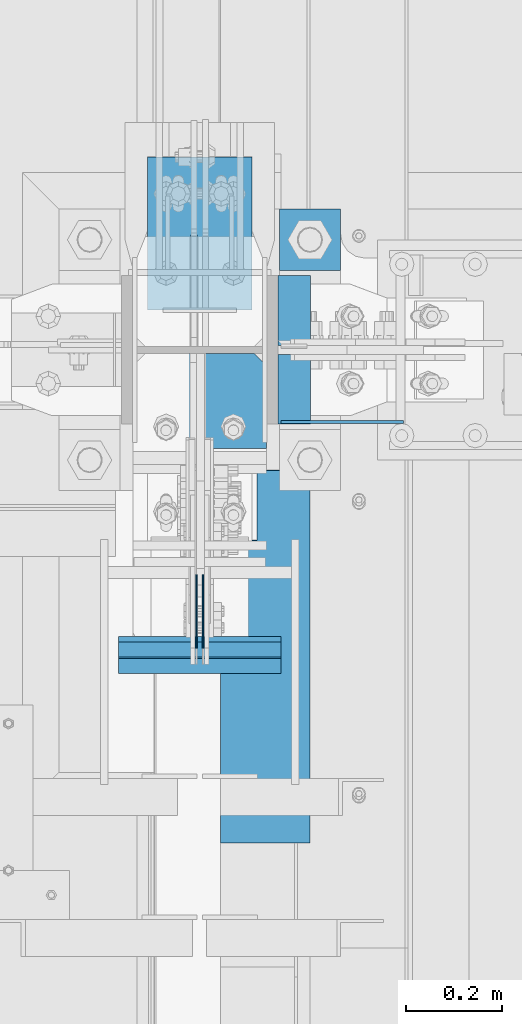
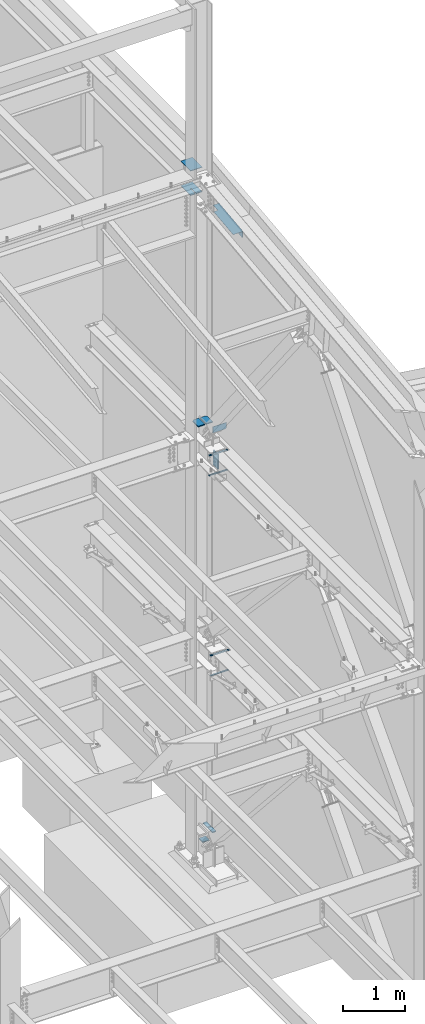
# One storey, part 894 of 1179: 15 beams, 7 elements without a shape of their own.
"""IFC2X3 building model written with IfcOpenShell, lengths in millimetres."""

from ifc_helpers import new_model, si_unit, frame, origin_with_axes, place, context, subcontext, project, spatial, faceted_brep, material, type_object, element, aggregate, save


model = new_model("IFC2X3")

# Units and contexts
model_context = context("Model", 3, precision=1e-05, world=origin_with_axes())
body_context = subcontext(model_context, "Body", "Model", "MODEL_VIEW")
ifc_project = project(units=[si_unit("LENGTHUNIT", "METRE", prefix="MILLI"), si_unit("AREAUNIT", "SQUARE_METRE"), si_unit("VOLUMEUNIT", "CUBIC_METRE"), si_unit("MASSUNIT", "GRAM", prefix="KILO"), si_unit("TIMEUNIT", "SECOND"), si_unit("PLANEANGLEUNIT", "RADIAN"), si_unit("SOLIDANGLEUNIT", "STERADIAN"), si_unit("THERMODYNAMICTEMPERATUREUNIT", "DEGREE_CELSIUS"), si_unit("LUMINOUSINTENSITYUNIT", "LUMEN")], contexts=[model_context])

# Site, building, storey
site_placement = place(None, origin_with_axes())
site = spatial("IfcSite", under=ifc_project, at=site_placement, CompositionType="ELEMENT")
building_placement = place(site_placement, origin_with_axes())
building = spatial("IfcBuilding", under=site, at=building_placement, Name="Undefined", CompositionType="ELEMENT")
storey_placement = place(building_placement, origin_with_axes())
storey = spatial("IfcBuildingStorey", under=building, at=storey_placement, Name="Undefined", CompositionType="ELEMENT", Elevation=0.0)

# Assembly, beam
assembly_1_placement = place(storey_placement, origin_with_axes())
assembly_1 = element("IfcElementAssembly", 1, at=assembly_1_placement, inside=storey, Name="TEMPLATE", AssemblyPlace="NOTDEFINED", PredefinedType="RIGID_FRAME")
ifc_material_1 = material(Name="STEEL/A36")
beam_type_1 = type_object("IfcBeamType", PredefinedType="NOTDEFINED")
beam_1_placement = place(assembly_1_placement, frame((24472.9, 34620.1999938965, -207.9625), z_axis=(0.0, 1.0, 0.0), x_axis=(1.0, 0.0, 0.0)))
beam_1 = element("IfcBeam", 2, at=beam_1_placement, type_object=beam_type_1, material=ifc_material_1, Name="SQ WASHER", context=body_context, shape_type="Brep", body=[
    faceted_brep([(0.0, 7.9375, -63.5), (0.0, 7.9375, 63.5), (127.0, 7.9375, 63.5), (127.0, 7.9375, -63.5), (0.0, -7.9375, 63.5), (127.0, -7.9375, 63.5), (0.0, -7.9375, -63.5), (127.0, -7.9375, -63.5)], [[[0, 1, 2, 3]], [[1, 4, 5, 2]], [[4, 6, 7, 5]], [[6, 0, 3, 7]], [[5, 7, 3, 2]], [[6, 4, 1, 0]]]),
])
aggregate(assembly_1, [beam_1])

# Assembly, beams
assembly_2_placement = place(storey_placement, origin_with_axes())
assembly_2 = element("IfcElementAssembly", 3, at=assembly_2_placement, inside=storey, Name="BEAM", AssemblyPlace="NOTDEFINED", PredefinedType="RIGID_FRAME")
ifc_material_2 = material(Name="STEEL/A572-GR.50")
beam_type_2 = type_object("IfcBeamType", PredefinedType="NOTDEFINED")
beam_2_placement = place(assembly_2_placement, frame((24307.8000366209, 33796.9036790882, 7589.8375), z_axis=(-1.0, 0.0, 0.0), x_axis=(0.0, -1.0, 0.0)))
beam_2 = element("IfcBeam", 4, at=beam_2_placement, type_object=beam_type_2, material=ifc_material_2, Name="PLATE", context=body_context, shape_type="Brep", body=[
    faceted_brep([(0.0, 4.76249999999982, -168.275000000001), (0.0, 4.76250000000073, 168.275), (31.75, 4.76249999999982, 168.275000000001), (31.75, 4.76249999999982, -168.275000000001), (0.0, -4.76250000000073, 168.275), (31.75, -4.76249999999982, 168.275000000001), (0.0, -4.76249999999982, -168.275000000001), (31.75, -4.76249999999982, -168.275000000001)], [[[0, 1, 2, 3]], [[1, 4, 5, 2]], [[4, 6, 7, 5]], [[6, 0, 3, 7]], [[5, 7, 3, 2]], [[6, 4, 1, 0]]]),
])
beam_3_placement = place(assembly_2_placement, frame((24307.8000366209, 33785.7911790881, 7989.4905), z_axis=(-1.0, 0.0, 0.0), x_axis=(0.0, -1.0, 0.0)))
beam_3 = element("IfcBeam", 5, at=beam_3_placement, type_object=beam_type_2, material=ifc_material_2, Name="PLATE", context=body_context, shape_type="Brep", body=[
    faceted_brep([(0.0, 4.76249999999982, -168.275000000001), (0.0, 4.76250000000073, 168.275), (31.75, 4.76249999999982, 168.275000000001), (31.75, 4.76249999999982, -168.275000000001), (0.0, -4.76250000000073, 168.275), (31.75, -4.76249999999982, 168.275000000001), (0.0, -4.76249999999982, -168.275000000001), (31.75, -4.76249999999982, -168.275000000001)], [[[0, 1, 2, 3]], [[1, 4, 5, 2]], [[4, 6, 7, 5]], [[6, 0, 3, 7]], [[5, 7, 3, 2]], [[6, 4, 1, 0]]]),
])

assembly_3_placement = place(storey_placement, origin_with_axes())
assembly_3 = element("IfcElementAssembly", 6, at=assembly_3_placement, inside=storey, Name="BEAM", AssemblyPlace="NOTDEFINED", PredefinedType="RIGID_FRAME")
beam_4_placement = place(assembly_3_placement, frame((24307.8000366209, 33762.7294989338, 3678.2375), z_axis=(-1.0, 0.0, 0.0), x_axis=(0.0, -1.0, 0.0)))
beam_4 = element("IfcBeam", 7, at=beam_4_placement, type_object=beam_type_2, material=ifc_material_2, Name="PLATE", context=body_context, shape_type="Brep", body=[
    faceted_brep([(0.0, 4.76249999999982, -168.275000000001), (0.0, 4.76250000000073, 168.275), (31.75, 4.76249999999982, 168.275000000001), (31.75, 4.76249999999982, -168.275000000001), (0.0, -4.76250000000073, 168.275), (31.75, -4.76249999999982, 168.275000000001), (0.0, -4.76249999999982, -168.275000000001), (31.75, -4.76249999999982, -168.275000000001)], [[[0, 1, 2, 3]], [[1, 4, 5, 2]], [[4, 6, 7, 5]], [[6, 0, 3, 7]], [[5, 7, 3, 2]], [[6, 4, 1, 0]]]),
])
beam_5_placement = place(assembly_3_placement, frame((24307.8000366209, 33751.6169989338, 4077.8905), z_axis=(-1.0, 0.0, 0.0), x_axis=(0.0, -1.0, 0.0)))
beam_5 = element("IfcBeam", 8, at=beam_5_placement, type_object=beam_type_2, material=ifc_material_2, Name="PLATE", context=body_context, shape_type="Brep", body=[
    faceted_brep([(0.0, 4.76249999999982, -168.275000000001), (0.0, 4.76250000000073, 168.275), (31.75, 4.76249999999982, 168.275000000001), (31.75, 4.76249999999982, -168.275000000001), (0.0, -4.76250000000073, 168.275), (31.75, -4.76249999999982, 168.275000000001), (0.0, -4.76249999999982, -168.275000000001), (31.75, -4.76249999999982, -168.275000000001)], [[[0, 1, 2, 3]], [[1, 4, 5, 2]], [[4, 6, 7, 5]], [[6, 0, 3, 7]], [[5, 7, 3, 2]], [[6, 4, 1, 0]]]),
])
aggregate(assembly_3, [beam_4, beam_5])

assembly_4_placement = place(storey_placement, origin_with_axes())
assembly_4 = element("IfcElementAssembly", 9, at=assembly_4_placement, inside=storey, Name="COLUMN", AssemblyPlace="NOTDEFINED", PredefinedType="RIGID_FRAME")
beam_type_3 = type_object("IfcBeamType", PredefinedType="NOTDEFINED")
beam_6_placement = place(assembly_4_placement, frame((24307.8000000207, 34474.9437499871, 12646.0249999739), z_axis=(1.0, 0.0, 0.0), x_axis=(0.0, 1.0, 0.0)))
beam_6 = element("IfcBeam", 10, at=beam_6_placement, type_object=beam_type_3, material=ifc_material_2, Name="PLATE", context=body_context, shape_type="Brep", body=[
    faceted_brep([(0.0, -6.35000000000036, -3.96874995145117), (0.0, 6.35000000000036, -3.96874995145117), (150.812500012864, 6.35000000000036, -3.96874995145117), (150.812500012864, -6.35000000000036, -3.96874995145117), (153.85004975726, 6.35000000000036, -4.57295616214105), (153.85004975726, -6.35000000000036, -4.57295616214105), (156.425160088533, 6.35000000000036, -6.29358987578235), (156.425160088533, -6.35000000000036, -6.29358987578235), (158.14579380217, 6.35000000000036, -8.86870020705464), (158.14579380217, -6.35000000000036, -8.86870020705464), (150.812500012864, -6.35000000000036, -19.8437499514512), (150.812500012864, 6.35000000000036, -19.8437499514512), (0.0, 6.35000000000036, -19.8437499514512), (0.0, -6.35000000000036, -19.8437499514512), (153.85004975726, -6.35000000000036, -19.2395437407613), (153.85004975726, 6.35000000000036, -19.2395437407613), (156.425160088533, -6.35000000000036, -17.51891002712), (156.425160088533, 6.35000000000036, -17.51891002712), (158.14579380217, -6.35000000000036, -14.9437996958477), (158.14579380217, 6.35000000000036, -14.9437996958477), (158.750000012864, -6.35000000000036, -11.9062499514512), (158.750000012864, 6.35000000000036, -11.9062499514512), (0.0, 6.35000000000036, 107.949999999997), (0.0, -6.35000000000036, 107.949999999997), (316.706250012867, -6.35000000000036, 107.949999999997), (316.706250012867, 6.35000000000036, 107.949999999997), (316.706250012867, -6.35000000000036, -107.949999999997), (316.706250012867, 6.35000000000036, -107.949999999997), (0.0, -6.35000000000036, -107.949999999997), (0.0, 6.35000000000036, -107.949999999997)], [[[0, 1, 2, 3]], [[3, 2, 4, 5]], [[5, 4, 6, 7]], [[7, 6, 8, 9]], [[10, 11, 12, 13]], [[14, 15, 11, 10]], [[16, 17, 15, 14]], [[18, 19, 17, 16]], [[20, 21, 19, 18]], [[9, 8, 21, 20]], [[22, 23, 24, 25]], [[24, 26, 27, 25]], [[28, 29, 27, 26]], [[29, 28, 13, 12]], [[6, 4, 2, 1, 22, 25, 27, 29, 12, 11, 15, 17, 19, 21, 8]], [[23, 22, 1, 0]], [[16, 14, 10, 13, 28, 26, 24, 23, 0, 3, 5, 7, 9, 20, 18]]]),
])
beam_7_placement = place(assembly_4_placement, frame((24307.8000000301, 34474.94375, 13125.449999951), z_axis=(1.0, 0.0, 0.0), x_axis=(0.0, 1.0, 0.0)))
beam_7 = element("IfcBeam", 11, at=beam_7_placement, type_object=beam_type_3, material=ifc_material_2, Name="PLATE", context=body_context, shape_type="Brep", body=[
    faceted_brep([(0.0, 6.35000000000036, -107.949999999997), (0.0, 6.35000000000036, 107.949999999997), (316.706250012867, 6.35000000000036, 107.949999999997), (316.706250012867, 6.35000000000036, -107.949999999997), (0.0, -6.35000000000036, 107.949999999997), (316.706250012867, -6.35000000000036, 107.949999999997), (0.0, -6.35000000000036, -107.949999999997), (316.706250012867, -6.35000000000036, -107.949999999997)], [[[0, 1, 2, 3]], [[1, 4, 5, 2]], [[4, 6, 7, 5]], [[6, 0, 3, 7]], [[5, 7, 3, 2]], [[6, 4, 1, 0]]]),
])

# Assembly, beam
assembly_5_placement = place(storey_placement, origin_with_axes())
assembly_5 = element("IfcElementAssembly", 12, at=assembly_5_placement, inside=storey, Name="PLATE", AssemblyPlace="NOTDEFINED", PredefinedType="RIGID_FRAME")
beam_type_4 = type_object("IfcBeamType", PredefinedType="NOTDEFINED")
beam_8_placement = place(assembly_5_placement, frame((24469.725, 34473.3565, 180.194274822156), z_axis=(0.0, 1.0, 0.0), x_axis=(1.0, 0.0, 0.0)))
beam_8 = element("IfcBeam", 13, at=beam_8_placement, type_object=beam_type_4, material=ifc_material_2, Name="PLATE", context=body_context, shape_type="Brep", body=[
    faceted_brep([(0.0, 9.52500000000001, -72.2315000000017), (0.0, 9.52500000000001, 72.2315000000017), (67.5930506080222, 9.52500000000001, 72.2315000000017), (67.5930506080222, 9.52500000000001, -72.2315000000017), (0.0, -9.52500000000001, 72.2315000000017), (67.5930506080222, -9.52500000000001, 72.2315000000017), (0.0, -9.52500000000001, -72.2315000000017), (67.5930506080222, -9.52500000000001, -72.2315000000017)], [[[0, 1, 2, 3]], [[1, 4, 5, 2]], [[4, 6, 7, 5]], [[6, 0, 3, 7]], [[5, 7, 3, 2]], [[6, 4, 1, 0]]]),
])
aggregate(assembly_5, [beam_8])

assembly_6_placement = place(storey_placement, origin_with_axes())
assembly_6 = element("IfcElementAssembly", 14, at=assembly_6_placement, inside=storey, Name="PLATE", AssemblyPlace="NOTDEFINED", PredefinedType="RIGID_FRAME")
beam_9_placement = place(assembly_6_placement, frame((24469.725, 34309.8435, 180.194274822156), z_axis=(0.0, -1.0, 0.0), x_axis=(1.0, 0.0, 0.0)))
beam_9 = element("IfcBeam", 15, at=beam_9_placement, type_object=beam_type_4, material=ifc_material_2, Name="PLATE", context=body_context, shape_type="Brep", body=[
    faceted_brep([(0.0, 9.52500000000001, -72.2315000000017), (0.0, 9.52500000000001, 72.2315000000017), (67.5930506080222, 9.52500000000001, 72.2315000000017), (67.5930506080222, 9.52500000000001, -72.2315000000017), (0.0, -9.52500000000001, 72.2315000000017), (67.5930506080222, -9.52500000000001, 72.2315000000017), (0.0, -9.52500000000001, -72.2315000000017), (67.5930506080222, -9.52500000000001, -72.2315000000017)], [[[0, 1, 2, 3]], [[1, 4, 5, 2]], [[4, 6, 7, 5]], [[6, 0, 3, 7]], [[5, 7, 3, 2]], [[6, 4, 1, 0]]]),
])
aggregate(assembly_6, [beam_9])

assembly_7_placement = place(storey_placement, origin_with_axes())
assembly_7 = element("IfcElementAssembly", 16, at=assembly_7_placement, inside=storey, Name="BEAM", AssemblyPlace="NOTDEFINED", PredefinedType="RIGID_FRAME")
beam_type_5 = type_object("IfcBeamType", PredefinedType="NOTDEFINED")
beam_10_placement = place(assembly_7_placement, frame((24350.6629999888, 33755.6342061002, 12535.6112616853), z_axis=(0.0, -0.993676146336441, -0.112284087038017), x_axis=(1.0, 0.0, 0.0)))
beam_10 = element("IfcBeam", 17, at=beam_10_placement, type_object=beam_type_5, material=ifc_material_1, Name="BENT_PLATE", context=body_context, shape_type="Brep", body=[
    faceted_brep([(76.1995000105744, -3.17611935630157, -242.887500005789), (76.1995000105744, 3.17449425745326, -242.887500003293), (76.1995000105744, 3.17499999987194, -388.937500001208), (76.1995000105744, -3.17500000012114, -388.937500001208), (-2.91038304567337e-11, -3.17500000019572, -242.887500005796), (-4.72937244921923e-11, 3.174999999801, -242.887500003293), (185.737000006415, 3.17500000077962, 388.93750000115), (5.45696821063757e-11, 3.17500000031578, 388.937500001186), (6.91215973347425e-11, -3.17499999968095, 388.937500001186), (179.387000006416, -3.17499999923166, 388.937500001157), (179.387000006314, -136.524999980484, 388.937500001179), (185.737000006313, -136.524999980484, 388.937500001179), (185.737000006124, 3.17500000014661, -388.937500001222), (185.737000006226, -136.524999980938, -388.937500001201), (179.387000006227, -136.524999980938, -388.937500001201), (179.387000006125, -3.17499999986467, -388.93750000123)], [[[0, 1, 2, 3]], [[4, 5, 1, 0]], [[6, 7, 8, 9, 10, 11]], [[12, 6, 11, 13]], [[10, 14, 13, 11]], [[9, 15, 14, 10]], [[12, 13, 14, 15, 3, 2]], [[7, 6, 12, 2, 1, 5]], [[8, 7, 5, 4]], [[15, 9, 8, 4, 0, 3]]]),
])
aggregate(assembly_7, [beam_10])

# Beam
beam_type_6 = type_object("IfcBeamType", PredefinedType="NOTDEFINED")
beam_11_placement = place(assembly_4_placement, frame((24233.981, 34186.8125, 8286.54312047043), z_axis=(-1.0, 0.0, 0.0), x_axis=(0.0, 1.0, 0.0)))
beam_11 = element("IfcBeam", 18, at=beam_11_placement, type_object=beam_type_6, material=ifc_material_2, Name="PLATE", context=body_context, shape_type="Brep", body=[
    faceted_brep([(197.427679164939, 9.52499999999964, 38.8940000000002), (172.027679164938, 9.52499999999964, 64.2940000000017), (172.027679164938, -9.52499999999964, 64.2940000000017), (197.427679164939, -9.52499999999964, 38.8940000000002), (197.427679164939, 9.52499999999964, -64.2940000000017), (0.0, 9.52500000000146, -64.2940000000017), (0.0, 9.52500000000146, 64.2940000000017), (0.0, -9.52500000000146, 64.2940000000017), (0.0, -9.52500000000146, -64.2940000000017), (197.427679164939, -9.52499999999964, -64.2940000000017)], [[[0, 1, 2, 3]], [[4, 5, 6, 1, 0]], [[6, 7, 2, 1]], [[7, 8, 9, 3, 2]], [[8, 5, 4, 9]], [[9, 4, 0, 3]], [[8, 7, 6, 5]]]),
])

beam_12_placement = place(assembly_4_placement, frame((24381.619, 34186.8125, 8286.54312047043), z_axis=(-1.0, 0.0, 0.0), x_axis=(0.0, 1.0, 0.0)))
beam_12 = element("IfcBeam", 19, at=beam_12_placement, type_object=beam_type_6, material=ifc_material_2, Name="PLATE", context=body_context, shape_type="Brep", body=[
    faceted_brep([(172.027679164938, 9.52499999999964, -64.2940000000017), (197.427679164939, 9.52499999999964, -38.8940000000002), (197.427679164939, -9.52499999999964, -38.8940000000002), (172.027679164938, -9.52499999999964, -64.2940000000017), (0.0, 9.52500000000146, -64.2940000000017), (0.0, 9.52500000000146, 64.2940000000017), (197.427679164939, 9.52499999999964, 64.2940000000017), (0.0, -9.52500000000146, 64.2940000000017), (197.427679164939, -9.52499999999964, 64.2940000000017), (0.0, -9.52500000000146, -64.2940000000017)], [[[0, 1, 2, 3]], [[4, 5, 6, 1, 0]], [[5, 7, 8, 6]], [[8, 7, 9, 3, 2]], [[9, 4, 0, 3]], [[6, 8, 2, 1]], [[9, 7, 5, 4]]]),
])

aggregate(assembly_4, [beam_6, beam_7, beam_11, beam_12])

beam_type_7 = type_object("IfcBeamType", PredefinedType="NOTDEFINED")
beam_13_placement = place(assembly_2_placement, frame((24300.65625, 33925.4911790881, 7804.15), z_axis=(0.0, 0.0, -1.0), x_axis=(0.0, -1.0, 0.0)))
beam_13 = element("IfcBeam", 20, at=beam_13_placement, type_object=beam_type_7, material=ifc_material_2, Name="PLATE", context=body_context, shape_type="Brep", body=[
    faceted_brep([(0.0, 1.58750000000146, -152.4), (0.0, 1.58750000000146, 152.4), (152.400000000009, 1.58750000000146, 152.4), (152.400000000009, 1.58750000000146, -152.4), (0.0, -1.58750000000146, 152.4), (152.400000000009, -1.58750000000146, 152.4), (0.0, -1.58750000000146, -152.4), (152.400000000009, -1.58750000000146, -152.4)], [[[0, 1, 2, 3]], [[1, 4, 5, 2]], [[4, 6, 7, 5]], [[6, 0, 3, 7]], [[5, 7, 3, 2]], [[6, 4, 1, 0]]]),
])

beam_14_placement = place(assembly_2_placement, frame((24314.94375, 33925.4911790881, 7804.15), z_axis=(0.0, 0.0, -1.0), x_axis=(0.0, -1.0, 0.0)))
beam_14 = element("IfcBeam", 21, at=beam_14_placement, type_object=beam_type_7, material=ifc_material_2, Name="PLATE", context=body_context, shape_type="Brep", body=[
    faceted_brep([(0.0, 1.58750000000146, -152.4), (0.0, 1.58750000000146, 152.4), (152.400000000009, 1.58750000000146, 152.4), (152.400000000009, 1.58750000000146, -152.4), (0.0, -1.58750000000146, 152.4), (152.400000000009, -1.58750000000146, 152.4), (0.0, -1.58750000000146, -152.4), (152.400000000009, -1.58750000000146, -152.4)], [[[0, 1, 2, 3]], [[1, 4, 5, 2]], [[4, 6, 7, 5]], [[6, 0, 3, 7]], [[5, 7, 3, 2]], [[6, 4, 1, 0]]]),
])

beam_type_8 = type_object("IfcBeamType", PredefinedType="NOTDEFINED")
beam_15_placement = place(assembly_2_placement, frame((24476.0749994349, 34242.3749998685, 8085.1375), z_axis=(0.0, 0.0, 1.0), x_axis=(1.0, 0.0, 0.0)))
beam_15 = element("IfcBeam", 22, at=beam_15_placement, type_object=beam_type_8, material=ifc_material_1, Name="PLATE", context=body_context, shape_type="Brep", body=[
    faceted_brep([(253.999994772013, -3.17499999977736, -42.8625000000002), (234.949994772014, -3.17499999978463, -61.9125000000004), (234.949994772011, 3.17500000021391, -61.9125000000004), (253.99999477201, 3.17500000022847, -42.8625000000002), (0.0, 3.17499999999927, -61.9125000000004), (0.0, 3.17499999999927, 61.9125000000004), (253.99999477201, 3.17500000022847, 61.9125000000004), (3.63797880709171e-12, -3.17499999999927, 61.9125000000004), (253.999994772013, -3.17499999977736, 61.9125000000004), (3.63797880709171e-12, -3.17499999999927, -61.9125000000004)], [[[0, 1, 2, 3]], [[4, 5, 6, 3, 2]], [[5, 7, 8, 6]], [[8, 7, 9, 1, 0]], [[9, 4, 2, 1]], [[6, 8, 0, 3]], [[9, 7, 5, 4]]]),
])

aggregate(assembly_2, [beam_2, beam_3, beam_13, beam_14, beam_15])

save(model, "model.ifc")
